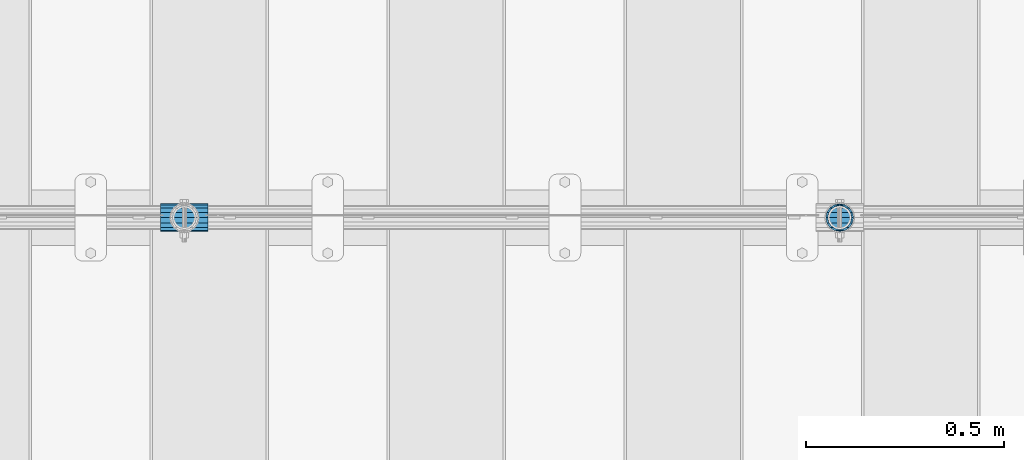
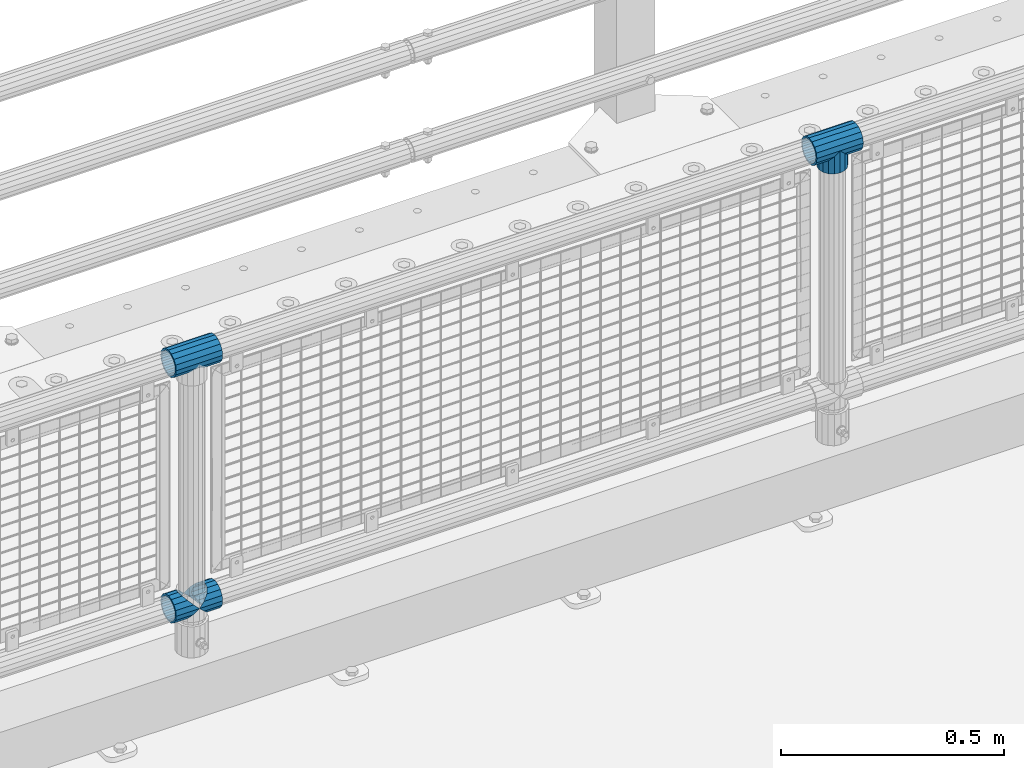
# One storey, part 149 of 240: 5 beams.
"""IFC2X3 building model written with IfcOpenShell, lengths in millimetres."""

from ifc_helpers import new_model, si_unit, frame, origin_with_axes, place, context, subcontext, project, spatial, faceted_brep, material, type_object, element, save


model = new_model("IFC2X3")

# Units and contexts
model_context = context("Model", 3, precision=1e-05, world=origin_with_axes())
body_context = subcontext(model_context, "Body", "Model", "MODEL_VIEW")
ifc_project = project(units=[si_unit("LENGTHUNIT", "METRE", prefix="MILLI"), si_unit("AREAUNIT", "SQUARE_METRE"), si_unit("VOLUMEUNIT", "CUBIC_METRE"), si_unit("MASSUNIT", "GRAM", prefix="KILO"), si_unit("TIMEUNIT", "SECOND"), si_unit("PLANEANGLEUNIT", "RADIAN"), si_unit("SOLIDANGLEUNIT", "STERADIAN"), si_unit("THERMODYNAMICTEMPERATUREUNIT", "DEGREE_CELSIUS"), si_unit("LUMINOUSINTENSITYUNIT", "LUMEN")], contexts=[model_context])

# Site, building, storey
site_placement = place(None, origin_with_axes())
site = spatial("IfcSite", under=ifc_project, at=site_placement, CompositionType="ELEMENT")
building_placement = place(site_placement, origin_with_axes())
building = spatial("IfcBuilding", under=site, at=building_placement, Name="Standard", CompositionType="ELEMENT")
storey_placement = place(building_placement, origin_with_axes())
storey = spatial("IfcBuildingStorey", under=building, at=storey_placement, Name="Undefined", CompositionType="ELEMENT", Elevation=0.0)

# Beams
ifc_material = material(Name="Misc_Undefined")
beam_type = type_object("IfcBeamType", PredefinedType="NOTDEFINED")
beam_1_placement = place(storey_placement, frame((48045.0, 34664.5, 969.849999999999), z_axis=(0.0, 1.0, 0.0), x_axis=(0.0, 0.0, -1.0)))
element("IfcBeam", 1, at=beam_1_placement, inside=storey, type_object=beam_type, material=ifc_material, context=body_context, shape_type="Brep", body=[
    faceted_brep([(0.0, 0.0, 35.1500000000015), (13.4513226476338, 13.4513226476329, 32.4743655677739), (13.4513226476338, -13.4513226476329, 32.4743655677739), (24.8548033587067, -16.3810424079947, -24.8548033587067), (24.8548033587067, -24.8548033587072, -24.8548033587067), (32.4743655677739, -32.4743655677717, -13.4513226476338), (32.4743655677739, -26.8123795176712, -13.4513226476338), (27.1226768591223, -21.4606908090117, -21.4606908090136), (0.0, 0.0, -35.1500000000015), (13.4513226476338, -13.4513226476329, -32.4743655677739), (13.4513226476338, 13.4513226476329, -32.4743655677739), (20.0882031229994, -11.6144421722805, -28.0397438117143), (16.6306603983758, 0.0, -30.3499999999985), (20.0882031229994, 11.6144421722805, -28.0397438117143), (24.8548033587067, 16.3810424080013, -24.8548033587067), (24.8548033587067, 24.8548033587072, -24.8548033587067), (27.1226768591223, 21.4606908090117, -21.4606908090136), (32.4743655677739, 26.8123795176712, -13.4513226476338), (32.4743655677739, 32.4743655677717, -13.4513226476338), (32.8397438117172, 28.0397438117175, -11.6144421722784), (35.1500000000015, 30.35, 0.0), (35.1500000000015, 35.15, 0.0), (32.8397438117099, 28.0397438117175, 11.6144421722784), (32.4743655677739, 26.8123795176755, 13.4513226476338), (32.4743655677739, 32.4743655677717, 13.4513226476338), (27.1226768591005, 21.4606908090117, 21.4606908090136), (24.8548033587067, 16.3810424080013, 24.8548033587067), (24.8548033587067, 24.8548033587072, 24.8548033587067), (20.0882031229849, 11.6144421722805, 28.0397438117143), (16.6306603983685, 0.0, 30.3499999999985), (20.0882031229849, -11.6144421722805, 28.0397438117143), (24.8548033587067, -16.3810424080078, 24.8548033587067), (24.8548033587067, -24.8548033587072, 24.8548033587067), (27.1226768591005, -21.4606908090117, 21.4606908090136), (32.4743655677739, -26.8123795176712, 13.4513226476338), (32.4743655677739, -32.4743655677717, 13.4513226476338), (32.8397438117099, -28.0397438117175, 11.6144421722784), (35.1500000000015, -30.35, 0.0), (35.1500000000015, -35.15, 0.0), (32.8397438117172, -28.0397438117175, -11.6144421722784), (60.1500000000015, -24.8548033587072, -24.8548033587067), (60.1500000000015, -32.4743655677717, -13.4513226476338), (60.1500000000015, -13.4513226476329, -32.4743655677739), (60.1500000000015, 0.0, -35.1500000000015), (60.1500000000015, 13.4513226476329, -32.4743655677739), (60.1500000000015, 24.8548033587072, -24.8548033587067), (60.1500000000015, 32.4743655677717, -13.4513226476338), (60.1500000000015, 35.15, 0.0), (60.1500000000015, 32.4743655677717, 13.4513226476338), (60.1500000000015, 24.8548033587072, 24.8548033587067), (60.1500000000015, 13.4513226476329, 32.4743655677739), (60.1500000000015, 0.0, 35.1500000000015), (60.1500000000015, -13.4513226476329, 32.4743655677739), (60.1500000000015, -24.8548033587072, 24.8548033587067), (60.1500000000015, -32.4743655677717, 13.4513226476338), (60.1500000000015, -35.15, 0.0), (60.1500000000015, -21.4606908090117, 21.4606908090136), (60.1500000000015, -11.6144421722805, 28.0397438117143), (60.1500000000015, 0.0, 30.3499999999985), (60.1500000000015, 11.6144421722805, 28.0397438117143), (60.1500000000015, 21.4606908090117, 21.4606908090136), (60.1500000000015, 28.0397438117175, 11.6144421722784), (60.1500000000015, 30.35, 0.0), (60.1500000000015, 28.0397438117175, -11.6144421722784), (60.1500000000015, 21.4606908090117, -21.4606908090136), (60.1500000000015, 11.6144421722805, -28.0397438117143), (60.1500000000015, 0.0, -30.3499999999985), (60.1500000000015, -11.6144421722805, -28.0397438117143), (60.1500000000015, -21.4606908090117, -21.4606908090136), (60.1500000000015, -28.0397438117175, -11.6144421722784), (60.1500000000015, -30.35, 0.0), (60.1500000000015, -28.0397438117175, 11.6144421722784)], [[[0, 1, 2]], [[3, 4, 5, 6, 7]], [[8, 9, 10]], [[10, 9, 4, 3, 11, 12, 13, 14, 15]], [[15, 14, 16, 17, 18]], [[18, 17, 19, 20, 21]], [[21, 20, 22, 23, 24]], [[24, 23, 25, 26, 27]], [[27, 26, 28, 29, 30, 31, 32, 2, 1]], [[33, 34, 35, 32, 31]], [[36, 37, 38, 35, 34]], [[6, 5, 38, 37, 39]], [[40, 41, 5, 4]], [[42, 40, 4, 9]], [[43, 42, 9, 8]], [[44, 43, 8, 10]], [[45, 44, 10, 15]], [[46, 45, 15, 18]], [[47, 46, 18, 21]], [[48, 47, 21, 24]], [[49, 48, 24, 27]], [[50, 49, 27, 1]], [[51, 50, 1, 0]], [[52, 51, 0, 2]], [[53, 52, 2, 32]], [[54, 53, 32, 35]], [[55, 54, 35, 38]], [[41, 55, 38, 5]], [[40, 42, 43, 44, 45, 46, 47, 48, 49, 50, 51, 52, 53, 54, 55, 41], [56, 57, 58, 59, 60, 61, 62, 63, 64, 65, 66, 67, 68, 69, 70, 71]], [[71, 70, 37, 36]], [[56, 71, 36, 34, 33]], [[57, 56, 33, 31, 30]], [[58, 57, 30, 29]], [[59, 58, 29, 28]], [[25, 60, 59, 28, 26]], [[22, 61, 60, 25, 23]], [[62, 61, 22, 20]], [[63, 62, 20, 19]], [[64, 63, 19, 17, 16]], [[65, 64, 16, 14, 13]], [[66, 65, 13, 12]], [[67, 66, 12, 11]], [[7, 68, 67, 11, 3]], [[39, 69, 68, 7, 6]], [[70, 69, 39, 37]]]),
])
beam_2_placement = place(storey_placement, frame((47984.85, 34664.5, 969.849999999999), z_axis=(0.0, 0.0, 1.0), x_axis=(1.0, 0.0, 0.0)))
element("IfcBeam", 2, at=beam_2_placement, inside=storey, type_object=beam_type, material=ifc_material, context=body_context, shape_type="Brep", body=[
    faceted_brep([(88.1897438117157, -11.6144421722784, -28.0397438117176), (88.1897438117157, -11.6144421722784, -32.8397438117188), (86.962379517674, -13.4513226476338, -32.4743655677718), (81.6106908090151, -21.4606908090136, -27.1226768591079), (81.6106908090151, -21.4606908090136, -21.4606908090117), (76.5310424080089, -24.8548033587067, -24.8548033587072), (71.7644421722798, -28.0397438117143, -20.0882031229927), (71.7644421722798, -28.0397438117143, -11.6144421722805), (60.1500000000015, -30.3499999999985, -16.6306603983737), (60.1500000000015, -30.35, 0.0), (48.5355578277231, -28.0397438117143, -20.0882031229927), (48.5355578277231, -28.0397438117143, -11.6144421722805), (43.7689575920012, -24.8548033587067, -24.8548033587072), (38.6893091909878, -21.4606908090136, -27.1226768591079), (38.6893091909878, -21.4606908090136, -21.4606908090117), (33.3376204823217, -13.4513226476338, -32.4743655677718), (32.1102561882872, -11.6144421722784, -32.8397438117188), (32.1102561882872, -11.6144421722784, -28.0397438117176), (29.8000000000029, 0.0, -35.15), (29.8000000000029, 0.0, -30.35), (32.1102561882872, 11.6144421722784, -32.8397438117188), (32.1102561882872, 11.6144421722784, -28.0397438117176), (33.3376204823362, 13.4513226476338, -32.4743655677718), (38.6893091909878, 21.4606908090136, -27.1226768591079), (38.6893091909878, 21.4606908090136, -21.4606908090117), (43.7689575919867, 24.8548033587067, -24.8548033587072), (48.5355578277231, 28.0397438117143, -20.0882031229927), (48.5355578277231, 28.0397438117143, -11.6144421722805), (60.1500000000015, 30.3499999999985, -16.6306603983737), (60.1500000000015, 30.35, 0.0), (71.7644421722798, 28.0397438117143, -20.0882031229927), (71.7644421722798, 28.0397438117143, -11.6144421722805), (76.5310424080017, 24.8548033587067, -24.8548033587072), (81.6106908090151, 21.4606908090136, -27.1226768591079), (81.6106908090151, 21.4606908090136, -21.4606908090117), (86.962379517674, 13.4513226476338, -32.4743655677718), (88.1897438117157, 11.6144421722784, -32.8397438117188), (88.1897438117157, 11.6144421722784, -28.0397438117176), (90.5, 0.0, -35.15), (90.5, 0.0, -30.35), (0.0, -21.4606908090136, -21.4606908090136), (0.0, -28.0397438117143, -11.6144421722784), (0.0, -11.6144421722784, -28.0397438117143), (0.0, 0.0, -30.3499999999985), (0.0, 11.6144421722784, -28.0397438117143), (0.0, 21.4606908090136, -21.4606908090136), (0.0, 28.0397438117143, -11.6144421722784), (0.0, 30.3499999999985, 0.0), (0.0, 32.4743655677739, -13.4513226476338), (0.0, 35.1500000000015, 0.0), (120.300000000003, 35.1500000000015, 0.0), (120.300000000003, 32.4743655677739, -13.4513226476329), (0.0, 32.4743655677739, 13.4513226476338), (120.300000000003, 32.4743655677739, 13.4513226476329), (0.0, 24.8548033587067, 24.8548033587067), (120.300000000003, 24.8548033587067, 24.8548033587072), (0.0, 13.4513226476338, 32.4743655677739), (120.300000000003, 13.4513226476338, 32.4743655677718), (0.0, 0.0, 35.1500000000015), (120.300000000003, 0.0, 35.15), (0.0, -13.4513226476338, 32.4743655677739), (120.300000000003, -13.4513226476338, 32.4743655677718), (0.0, -24.8548033587067, 24.8548033587067), (120.300000000003, -24.8548033587067, 24.8548033587072), (0.0, -32.4743655677739, 13.4513226476338), (120.300000000003, -32.4743655677739, 13.4513226476329), (0.0, -35.1500000000015, 0.0), (120.300000000003, -35.1500000000015, 0.0), (0.0, -32.4743655677739, -13.4513226476338), (120.300000000003, -32.4743655677739, -13.4513226476329), (0.0, 24.8548033587067, -24.8548033587067), (0.0, 13.4513226476338, -32.4743655677739), (0.0, 0.0, -35.1500000000015), (0.0, -13.4513226476338, -32.4743655677739), (0.0, -24.8548033587067, -24.8548033587067), (0.0, 28.0397438117143, 11.6144421722784), (0.0, 21.4606908090136, 21.4606908090136), (0.0, 11.6144421722784, 28.0397438117143), (0.0, 0.0, 30.3499999999985), (0.0, -11.6144421722784, 28.0397438117143), (0.0, -21.4606908090136, 21.4606908090136), (0.0, -28.0397438117143, 11.6144421722784), (0.0, -30.3499999999985, 0.0), (120.300000000003, -30.3499999999985, 0.0), (120.300000000003, -28.0397438117143, -11.6144421722805), (120.300000000003, -21.4606908090136, -21.4606908090117), (120.300000000003, -11.6144421722784, -28.0397438117176), (120.300000000003, 0.0, -30.35), (120.300000000003, 21.4606908090136, -21.4606908090117), (120.300000000003, 28.0397438117143, -11.6144421722805), (120.300000000003, 11.6144421722784, -28.0397438117176), (120.300000000003, 30.3499999999985, 0.0), (120.300000000003, 28.0397438117143, 11.6144421722805), (120.300000000003, 21.4606908090136, 21.4606908090117), (120.300000000003, 11.6144421722784, 28.0397438117176), (120.300000000003, 0.0, 30.35), (120.300000000003, -11.6144421722784, 28.0397438117176), (120.300000000003, -21.4606908090136, 21.4606908090117), (120.300000000003, -28.0397438117143, 11.6144421722805), (120.300000000003, -24.8548033587067, -24.8548033587072), (120.300000000003, -13.4513226476338, -32.4743655677718), (120.300000000003, 0.0, -35.15), (120.300000000003, 13.4513226476338, -32.4743655677718), (120.300000000003, 24.8548033587067, -24.8548033587072)], [[[0, 1, 2, 3, 4]], [[4, 3, 5, 6, 7]], [[7, 6, 8, 9]], [[9, 8, 10, 11]], [[11, 10, 12, 13, 14]], [[14, 13, 15, 16, 17]], [[17, 16, 18, 19]], [[19, 18, 20, 21]], [[21, 20, 22, 23, 24]], [[24, 23, 25, 26, 27]], [[27, 26, 28, 29]], [[29, 28, 30, 31]], [[31, 30, 32, 33, 34]], [[34, 33, 35, 36, 37]], [[37, 36, 38, 39]], [[39, 38, 1, 0]], [[40, 41, 11, 14]], [[42, 40, 14, 17]], [[43, 42, 17, 19]], [[44, 43, 19, 21]], [[45, 44, 21, 24]], [[46, 45, 24, 27]], [[47, 46, 27, 29]], [[48, 49, 50, 51]], [[49, 52, 53, 50]], [[52, 54, 55, 53]], [[54, 56, 57, 55]], [[56, 58, 59, 57]], [[58, 60, 61, 59]], [[60, 62, 63, 61]], [[62, 64, 65, 63]], [[64, 66, 67, 65]], [[66, 68, 69, 67]], [[64, 62, 60, 58, 56, 54, 52, 49, 48, 70, 71, 72, 73, 74, 68, 66], [41, 40, 42, 43, 44, 45, 46, 47, 75, 76, 77, 78, 79, 80, 81, 82]], [[41, 82, 9, 11]], [[83, 84, 7, 9]], [[84, 85, 4, 7]], [[85, 86, 0, 4]], [[86, 87, 39, 0]], [[88, 89, 31, 34]], [[90, 88, 34, 37]], [[87, 90, 37, 39]], [[89, 91, 29, 31]], [[75, 47, 29, 91, 92]], [[76, 75, 92, 93]], [[77, 76, 93, 94]], [[78, 77, 94, 95]], [[79, 78, 95, 96]], [[80, 79, 96, 97]], [[81, 80, 97, 98]], [[9, 82, 81, 98, 83]], [[99, 100, 101, 102, 103, 51, 50, 53, 55, 57, 59, 61, 63, 65, 67, 69], [97, 96, 95, 94, 93, 92, 91, 89, 88, 90, 87, 86, 85, 84, 83, 98]], [[35, 102, 101, 38, 36]], [[32, 103, 102, 35, 33]], [[28, 26, 25, 70, 48, 51, 103, 32, 30]], [[22, 71, 70, 25, 23]], [[18, 72, 71, 22, 20]], [[73, 72, 18, 16, 15]], [[74, 73, 15, 13, 12]], [[99, 69, 68, 74, 12, 10, 8, 6, 5]], [[100, 99, 5, 3, 2]], [[101, 100, 2, 1, 38]]]),
])
beam_3_placement = place(storey_placement, frame((46326.85, 34664.5, 969.849999999999), z_axis=(0.0, 0.0, 1.0), x_axis=(1.0, 0.0, 0.0)))
element("IfcBeam", 3, at=beam_3_placement, inside=storey, type_object=beam_type, material=ifc_material, context=body_context, shape_type="Brep", body=[
    faceted_brep([(88.1897438117157, -11.6144421722784, -28.0397438117176), (88.1897438117157, -11.6144421722784, -32.8397438117188), (86.962379517674, -13.4513226476338, -32.4743655677718), (81.6106908090151, -21.4606908090136, -27.1226768591079), (81.6106908090151, -21.4606908090136, -21.4606908090117), (76.5310424080089, -24.8548033587067, -24.8548033587072), (71.7644421722798, -28.0397438117143, -20.0882031229927), (71.7644421722798, -28.0397438117143, -11.6144421722805), (60.1500000000015, -30.3499999999985, -16.6306603983737), (60.1500000000015, -30.35, 0.0), (48.5355578277231, -28.0397438117143, -20.0882031229927), (48.5355578277231, -28.0397438117143, -11.6144421722805), (43.7689575920012, -24.8548033587067, -24.8548033587072), (38.6893091909878, -21.4606908090136, -27.1226768591079), (38.6893091909878, -21.4606908090136, -21.4606908090117), (33.3376204823217, -13.4513226476338, -32.4743655677718), (32.1102561882872, -11.6144421722784, -32.8397438117188), (32.1102561882872, -11.6144421722784, -28.0397438117176), (29.8000000000029, 0.0, -35.15), (29.8000000000029, 0.0, -30.35), (32.1102561882872, 11.6144421722784, -32.8397438117188), (32.1102561882872, 11.6144421722784, -28.0397438117176), (33.3376204823362, 13.4513226476338, -32.4743655677718), (38.6893091909878, 21.4606908090136, -27.1226768591079), (38.6893091909878, 21.4606908090136, -21.4606908090117), (43.7689575919867, 24.8548033587067, -24.8548033587072), (48.5355578277231, 28.0397438117143, -20.0882031229927), (48.5355578277231, 28.0397438117143, -11.6144421722805), (60.1500000000015, 30.3499999999985, -16.6306603983737), (60.1500000000015, 30.35, 0.0), (71.7644421722798, 28.0397438117143, -20.0882031229927), (71.7644421722798, 28.0397438117143, -11.6144421722805), (76.5310424080017, 24.8548033587067, -24.8548033587072), (81.6106908090151, 21.4606908090136, -27.1226768591079), (81.6106908090151, 21.4606908090136, -21.4606908090117), (86.962379517674, 13.4513226476338, -32.4743655677718), (88.1897438117157, 11.6144421722784, -32.8397438117188), (88.1897438117157, 11.6144421722784, -28.0397438117176), (90.5, 0.0, -35.15), (90.5, 0.0, -30.35), (0.0, -21.4606908090136, -21.4606908090136), (0.0, -28.0397438117143, -11.6144421722784), (0.0, -11.6144421722784, -28.0397438117143), (0.0, 0.0, -30.3499999999985), (0.0, 11.6144421722784, -28.0397438117143), (0.0, 21.4606908090136, -21.4606908090136), (0.0, 28.0397438117143, -11.6144421722784), (0.0, 30.3499999999985, 0.0), (0.0, 32.4743655677739, -13.4513226476338), (0.0, 35.1500000000015, 0.0), (120.300000000003, 35.1500000000015, 0.0), (120.300000000003, 32.4743655677739, -13.4513226476329), (0.0, 32.4743655677739, 13.4513226476338), (120.300000000003, 32.4743655677739, 13.4513226476329), (0.0, 24.8548033587067, 24.8548033587067), (120.300000000003, 24.8548033587067, 24.8548033587072), (0.0, 13.4513226476338, 32.4743655677739), (120.300000000003, 13.4513226476338, 32.4743655677718), (0.0, 0.0, 35.1500000000015), (120.300000000003, 0.0, 35.15), (0.0, -13.4513226476338, 32.4743655677739), (120.300000000003, -13.4513226476338, 32.4743655677718), (0.0, -24.8548033587067, 24.8548033587067), (120.300000000003, -24.8548033587067, 24.8548033587072), (0.0, -32.4743655677739, 13.4513226476338), (120.300000000003, -32.4743655677739, 13.4513226476329), (0.0, -35.1500000000015, 0.0), (120.300000000003, -35.1500000000015, 0.0), (0.0, -32.4743655677739, -13.4513226476338), (120.300000000003, -32.4743655677739, -13.4513226476329), (0.0, 24.8548033587067, -24.8548033587067), (0.0, 13.4513226476338, -32.4743655677739), (0.0, 0.0, -35.1500000000015), (0.0, -13.4513226476338, -32.4743655677739), (0.0, -24.8548033587067, -24.8548033587067), (0.0, 28.0397438117143, 11.6144421722784), (0.0, 21.4606908090136, 21.4606908090136), (0.0, 11.6144421722784, 28.0397438117143), (0.0, 0.0, 30.3499999999985), (0.0, -11.6144421722784, 28.0397438117143), (0.0, -21.4606908090136, 21.4606908090136), (0.0, -28.0397438117143, 11.6144421722784), (0.0, -30.3499999999985, 0.0), (120.300000000003, -30.3499999999985, 0.0), (120.300000000003, -28.0397438117143, -11.6144421722805), (120.300000000003, -21.4606908090136, -21.4606908090117), (120.300000000003, -11.6144421722784, -28.0397438117176), (120.300000000003, 0.0, -30.35), (120.300000000003, 21.4606908090136, -21.4606908090117), (120.300000000003, 28.0397438117143, -11.6144421722805), (120.300000000003, 11.6144421722784, -28.0397438117176), (120.300000000003, 30.3499999999985, 0.0), (120.300000000003, 28.0397438117143, 11.6144421722805), (120.300000000003, 21.4606908090136, 21.4606908090117), (120.300000000003, 11.6144421722784, 28.0397438117176), (120.300000000003, 0.0, 30.35), (120.300000000003, -11.6144421722784, 28.0397438117176), (120.300000000003, -21.4606908090136, 21.4606908090117), (120.300000000003, -28.0397438117143, 11.6144421722805), (120.300000000003, -24.8548033587067, -24.8548033587072), (120.300000000003, -13.4513226476338, -32.4743655677718), (120.300000000003, 0.0, -35.15), (120.300000000003, 13.4513226476338, -32.4743655677718), (120.300000000003, 24.8548033587067, -24.8548033587072)], [[[0, 1, 2, 3, 4]], [[4, 3, 5, 6, 7]], [[7, 6, 8, 9]], [[9, 8, 10, 11]], [[11, 10, 12, 13, 14]], [[14, 13, 15, 16, 17]], [[17, 16, 18, 19]], [[19, 18, 20, 21]], [[21, 20, 22, 23, 24]], [[24, 23, 25, 26, 27]], [[27, 26, 28, 29]], [[29, 28, 30, 31]], [[31, 30, 32, 33, 34]], [[34, 33, 35, 36, 37]], [[37, 36, 38, 39]], [[39, 38, 1, 0]], [[40, 41, 11, 14]], [[42, 40, 14, 17]], [[43, 42, 17, 19]], [[44, 43, 19, 21]], [[45, 44, 21, 24]], [[46, 45, 24, 27]], [[47, 46, 27, 29]], [[48, 49, 50, 51]], [[49, 52, 53, 50]], [[52, 54, 55, 53]], [[54, 56, 57, 55]], [[56, 58, 59, 57]], [[58, 60, 61, 59]], [[60, 62, 63, 61]], [[62, 64, 65, 63]], [[64, 66, 67, 65]], [[66, 68, 69, 67]], [[64, 62, 60, 58, 56, 54, 52, 49, 48, 70, 71, 72, 73, 74, 68, 66], [41, 40, 42, 43, 44, 45, 46, 47, 75, 76, 77, 78, 79, 80, 81, 82]], [[41, 82, 9, 11]], [[83, 84, 7, 9]], [[84, 85, 4, 7]], [[85, 86, 0, 4]], [[86, 87, 39, 0]], [[88, 89, 31, 34]], [[90, 88, 34, 37]], [[87, 90, 37, 39]], [[89, 91, 29, 31]], [[75, 47, 29, 91, 92]], [[76, 75, 92, 93]], [[77, 76, 93, 94]], [[78, 77, 94, 95]], [[79, 78, 95, 96]], [[80, 79, 96, 97]], [[81, 80, 97, 98]], [[9, 82, 81, 98, 83]], [[99, 100, 101, 102, 103, 51, 50, 53, 55, 57, 59, 61, 63, 65, 67, 69], [97, 96, 95, 94, 93, 92, 91, 89, 88, 90, 87, 86, 85, 84, 83, 98]], [[35, 102, 101, 38, 36]], [[32, 103, 102, 35, 33]], [[28, 26, 25, 70, 48, 51, 103, 32, 30]], [[22, 71, 70, 25, 23]], [[18, 72, 71, 22, 20]], [[73, 72, 18, 16, 15]], [[74, 73, 15, 13, 12]], [[99, 69, 68, 74, 12, 10, 8, 6, 5]], [[100, 99, 5, 3, 2]], [[101, 100, 2, 1, 38]]]),
])
beam_4_placement = place(storey_placement, frame((46326.85, 34664.5, 298.17), z_axis=(0.0, 1.0, 0.0), x_axis=(1.0, 0.0, 0.0)))
element("IfcBeam", 4, at=beam_4_placement, inside=storey, type_object=beam_type, material=ifc_material, context=body_context, shape_type="Brep", body=[
    faceted_brep([(60.1500000000015, 0.0, -35.1500000000015), (46.6986773523677, 13.4513226476329, -32.4743655677739), (46.6986773523677, -13.4513226476329, -32.4743655677739), (33.0273231408937, 21.4606908090117, 21.4606908090136), (27.6756344322275, 26.8123795176712, 13.4513226476338), (27.6756344322275, 32.4743655677717, 13.4513226476338), (35.2951966412948, 24.8548033587072, 24.8548033587067), (35.2951966412948, 16.3810424080013, 24.8548033587067), (27.3102561882843, 28.0397438117175, 11.6144421722784), (25.0, 30.35, 0.0), (25.0, 35.15, 0.0), (27.6756344322275, 26.8123795176712, -13.4513226476338), (27.6756344322275, 32.4743655677717, -13.4513226476338), (27.3102561882843, 28.0397438117175, -11.6144421722784), (35.2951966412948, 16.3810424080078, -24.8548033587067), (35.2951966412948, 24.8548033587072, -24.8548033587067), (33.0273231408937, 21.4606908090117, -21.4606908090136), (40.0617968770021, 11.6144421722805, -28.0397438117143), (43.5193396016257, 0.0, -30.3499999999985), (40.0617968770021, -11.6144421722805, -28.0397438117143), (35.2951966412948, -16.3810424079948, -24.8548033587067), (35.2951966412948, -24.8548033587072, -24.8548033587067), (33.0273231408937, -21.4606908090117, -21.4606908090136), (27.6756344322275, -26.8123795176755, -13.4513226476338), (27.6756344322275, -32.4743655677717, -13.4513226476338), (27.3102561882843, -28.0397438117175, -11.6144421722784), (25.0, -30.35, 0.0), (25.0, -35.15, 0.0), (27.3102561882843, -28.0397438117175, 11.6144421722784), (27.6756344322275, -26.8123795176712, 13.4513226476338), (27.6756344322275, -32.4743655677717, 13.4513226476338), (33.0273231408937, -21.4606908090117, 21.4606908090136), (35.2951966412948, -16.3810424080078, 24.8548033587067), (35.2951966412948, -24.8548033587072, 24.8548033587067), (60.1500000000015, 0.0, 35.1500000000015), (46.6986773523677, -13.4513226476329, 32.4743655677739), (46.6986773523677, 13.4513226476329, 32.4743655677739), (40.0617968770093, -11.6144421722805, 28.0397438117143), (43.5193396016257, 0.0, 30.3499999999985), (40.0617968770093, 11.6144421722805, 28.0397438117143), (0.0, -32.4743655677739, -13.4513226476338), (0.0, -24.8548033587067, -24.8548033587067), (0.0, -13.4513226476338, -32.4743655677739), (0.0, 0.0, -35.1500000000015), (0.0, 13.4513226476338, -32.4743655677739), (0.0, 24.8548033587067, -24.8548033587067), (0.0, 32.4743655677739, -13.4513226476338), (0.0, 35.1500000000015, 0.0), (0.0, 32.4743655677739, 13.4513226476338), (0.0, 24.8548033587067, 24.8548033587067), (0.0, 13.4513226476338, 32.4743655677739), (0.0, 0.0, 35.1500000000015), (0.0, -32.4743655677739, 13.4513226476338), (0.0, -35.1500000000015, 0.0), (0.0, -24.8548033587067, 24.8548033587067), (0.0, -13.4513226476338, 32.4743655677739), (0.0, -28.0397438117143, -11.6144421722784), (0.0, -21.4606908090136, -21.4606908090136), (0.0, -11.6144421722784, -28.0397438117143), (0.0, 0.0, -30.3499999999985), (0.0, 11.6144421722784, -28.0397438117143), (0.0, 21.4606908090136, -21.4606908090136), (0.0, 28.0397438117143, -11.6144421722784), (0.0, 30.3499999999985, 0.0), (0.0, 28.0397438117143, 11.6144421722784), (0.0, 21.4606908090136, 21.4606908090136), (0.0, 11.6144421722784, 28.0397438117143), (0.0, 0.0, 30.3499999999985), (0.0, -11.6144421722784, 28.0397438117143), (0.0, -21.4606908090136, 21.4606908090136), (0.0, -28.0397438117143, 11.6144421722784), (0.0, -30.3499999999985, 0.0)], [[[0, 1, 2]], [[3, 4, 5, 6, 7]], [[8, 9, 10, 5, 4]], [[11, 12, 10, 9, 13]], [[14, 15, 12, 11, 16]], [[2, 1, 15, 14, 17, 18, 19, 20, 21]], [[21, 20, 22, 23, 24]], [[24, 23, 25, 26, 27]], [[27, 26, 28, 29, 30]], [[30, 29, 31, 32, 33]], [[34, 35, 36]], [[33, 32, 37, 38, 39, 7, 6, 36, 35]], [[40, 41, 21, 24]], [[41, 42, 2, 21]], [[42, 43, 0, 2]], [[43, 44, 1, 0]], [[44, 45, 15, 1]], [[45, 46, 12, 15]], [[46, 47, 10, 12]], [[47, 48, 5, 10]], [[48, 49, 6, 5]], [[49, 50, 36, 6]], [[50, 51, 34, 36]], [[52, 53, 27, 30]], [[54, 52, 30, 33]], [[55, 54, 33, 35]], [[51, 55, 35, 34]], [[53, 40, 24, 27]], [[52, 54, 55, 51, 50, 49, 48, 47, 46, 45, 44, 43, 42, 41, 40, 53], [56, 57, 58, 59, 60, 61, 62, 63, 64, 65, 66, 67, 68, 69, 70, 71]], [[68, 67, 38, 37]], [[31, 69, 68, 37, 32]], [[28, 70, 69, 31, 29]], [[71, 70, 28, 26]], [[56, 71, 26, 25]], [[57, 56, 25, 23, 22]], [[58, 57, 22, 20, 19]], [[59, 58, 19, 18]], [[60, 59, 18, 17]], [[16, 61, 60, 17, 14]], [[13, 62, 61, 16, 11]], [[63, 62, 13, 9]], [[64, 63, 9, 8]], [[65, 64, 8, 4, 3]], [[66, 65, 3, 7, 39]], [[67, 66, 39, 38]]]),
])
beam_5_placement = place(storey_placement, frame((46387.0, 34664.5, 298.17), z_axis=(0.0, 1.0, 0.0), x_axis=(1.0, 0.0, 0.0)))
element("IfcBeam", 5, at=beam_5_placement, inside=storey, type_object=beam_type, material=ifc_material, context=body_context, shape_type="Brep", body=[
    faceted_brep([(0.0, 0.0, 35.1500000000015), (13.4513226476338, 13.4513226476329, 32.4743655677739), (13.4513226476338, -13.4513226476329, 32.4743655677739), (24.8548033587067, -16.3810424079947, -24.8548033587067), (24.8548033587067, -24.8548033587072, -24.8548033587067), (32.4743655677739, -32.4743655677717, -13.4513226476338), (32.4743655677739, -26.8123795176712, -13.4513226476338), (27.1226768591223, -21.4606908090117, -21.4606908090136), (0.0, 0.0, -35.1500000000015), (13.4513226476338, -13.4513226476329, -32.4743655677739), (13.4513226476338, 13.4513226476329, -32.4743655677739), (20.0882031229994, -11.6144421722805, -28.0397438117143), (16.6306603983758, 0.0, -30.3499999999985), (20.0882031229994, 11.6144421722805, -28.0397438117143), (24.8548033587067, 16.3810424080013, -24.8548033587067), (24.8548033587067, 24.8548033587072, -24.8548033587067), (27.1226768591223, 21.4606908090117, -21.4606908090136), (32.4743655677739, 26.8123795176712, -13.4513226476338), (32.4743655677739, 32.4743655677717, -13.4513226476338), (32.8397438117172, 28.0397438117175, -11.6144421722784), (35.1500000000015, 30.35, 0.0), (35.1500000000015, 35.15, 0.0), (32.8397438117099, 28.0397438117175, 11.6144421722784), (32.4743655677739, 26.8123795176755, 13.4513226476338), (32.4743655677739, 32.4743655677717, 13.4513226476338), (27.1226768591005, 21.4606908090117, 21.4606908090136), (24.8548033587067, 16.3810424080013, 24.8548033587067), (24.8548033587067, 24.8548033587072, 24.8548033587067), (20.0882031229849, 11.6144421722805, 28.0397438117143), (16.6306603983685, 0.0, 30.3499999999985), (20.0882031229849, -11.6144421722805, 28.0397438117143), (24.8548033587067, -16.3810424080078, 24.8548033587067), (24.8548033587067, -24.8548033587072, 24.8548033587067), (27.1226768591005, -21.4606908090117, 21.4606908090136), (32.4743655677739, -26.8123795176712, 13.4513226476338), (32.4743655677739, -32.4743655677717, 13.4513226476338), (32.8397438117099, -28.0397438117175, 11.6144421722784), (35.1500000000015, -30.35, 0.0), (35.1500000000015, -35.15, 0.0), (32.8397438117172, -28.0397438117175, -11.6144421722784), (60.1500000000015, -24.8548033587072, -24.8548033587067), (60.1500000000015, -32.4743655677717, -13.4513226476338), (60.1500000000015, -13.4513226476329, -32.4743655677739), (60.1500000000015, 0.0, -35.1500000000015), (60.1500000000015, 13.4513226476329, -32.4743655677739), (60.1500000000015, 24.8548033587072, -24.8548033587067), (60.1500000000015, 32.4743655677717, -13.4513226476338), (60.1500000000015, 35.15, 0.0), (60.1500000000015, 32.4743655677717, 13.4513226476338), (60.1500000000015, 24.8548033587072, 24.8548033587067), (60.1500000000015, 13.4513226476329, 32.4743655677739), (60.1500000000015, 0.0, 35.1500000000015), (60.1500000000015, -13.4513226476329, 32.4743655677739), (60.1500000000015, -24.8548033587072, 24.8548033587067), (60.1500000000015, -32.4743655677717, 13.4513226476338), (60.1500000000015, -35.15, 0.0), (60.1500000000015, -21.4606908090117, 21.4606908090136), (60.1500000000015, -11.6144421722805, 28.0397438117143), (60.1500000000015, 0.0, 30.3499999999985), (60.1500000000015, 11.6144421722805, 28.0397438117143), (60.1500000000015, 21.4606908090117, 21.4606908090136), (60.1500000000015, 28.0397438117175, 11.6144421722784), (60.1500000000015, 30.35, 0.0), (60.1500000000015, 28.0397438117175, -11.6144421722784), (60.1500000000015, 21.4606908090117, -21.4606908090136), (60.1500000000015, 11.6144421722805, -28.0397438117143), (60.1500000000015, 0.0, -30.3499999999985), (60.1500000000015, -11.6144421722805, -28.0397438117143), (60.1500000000015, -21.4606908090117, -21.4606908090136), (60.1500000000015, -28.0397438117175, -11.6144421722784), (60.1500000000015, -30.35, 0.0), (60.1500000000015, -28.0397438117175, 11.6144421722784)], [[[0, 1, 2]], [[3, 4, 5, 6, 7]], [[8, 9, 10]], [[10, 9, 4, 3, 11, 12, 13, 14, 15]], [[15, 14, 16, 17, 18]], [[18, 17, 19, 20, 21]], [[21, 20, 22, 23, 24]], [[24, 23, 25, 26, 27]], [[27, 26, 28, 29, 30, 31, 32, 2, 1]], [[33, 34, 35, 32, 31]], [[36, 37, 38, 35, 34]], [[6, 5, 38, 37, 39]], [[40, 41, 5, 4]], [[42, 40, 4, 9]], [[43, 42, 9, 8]], [[44, 43, 8, 10]], [[45, 44, 10, 15]], [[46, 45, 15, 18]], [[47, 46, 18, 21]], [[48, 47, 21, 24]], [[49, 48, 24, 27]], [[50, 49, 27, 1]], [[51, 50, 1, 0]], [[52, 51, 0, 2]], [[53, 52, 2, 32]], [[54, 53, 32, 35]], [[55, 54, 35, 38]], [[41, 55, 38, 5]], [[40, 42, 43, 44, 45, 46, 47, 48, 49, 50, 51, 52, 53, 54, 55, 41], [56, 57, 58, 59, 60, 61, 62, 63, 64, 65, 66, 67, 68, 69, 70, 71]], [[71, 70, 37, 36]], [[56, 71, 36, 34, 33]], [[57, 56, 33, 31, 30]], [[58, 57, 30, 29]], [[59, 58, 29, 28]], [[25, 60, 59, 28, 26]], [[22, 61, 60, 25, 23]], [[62, 61, 22, 20]], [[63, 62, 20, 19]], [[64, 63, 19, 17, 16]], [[65, 64, 16, 14, 13]], [[66, 65, 13, 12]], [[67, 66, 12, 11]], [[7, 68, 67, 11, 3]], [[39, 69, 68, 7, 6]], [[70, 69, 39, 37]]]),
])

save(model, "model.ifc")
